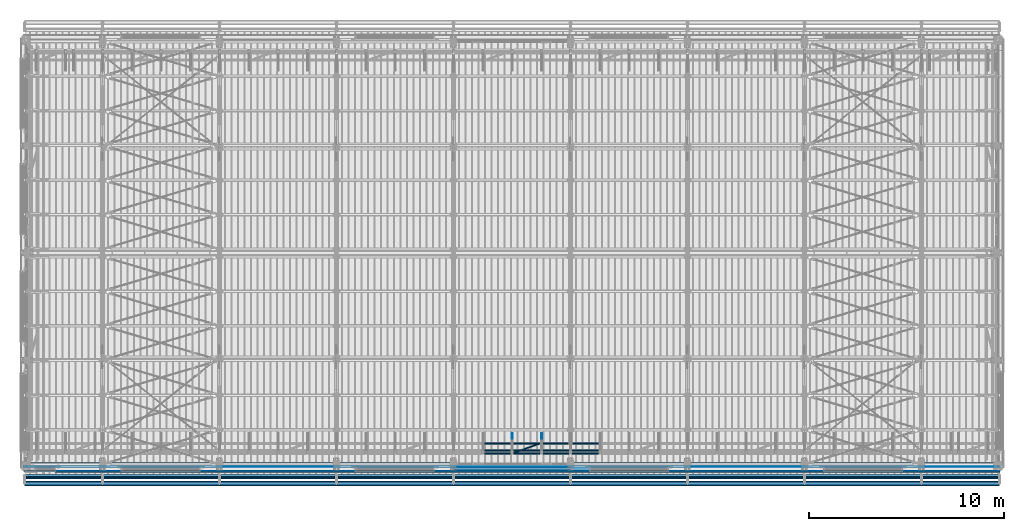
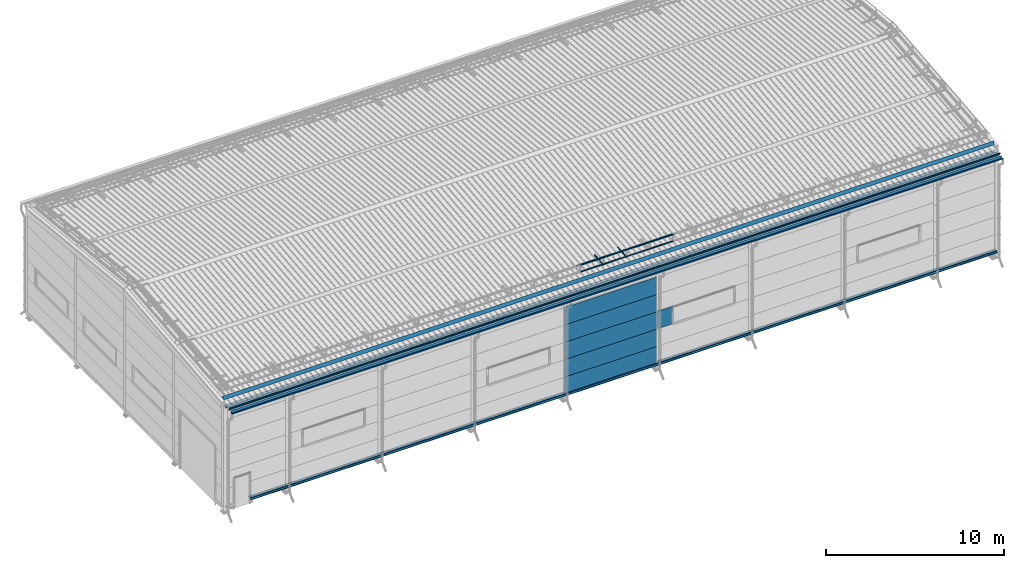
# One storey, part 44 of 709: 21 beams, 21 elements without a shape of their own.
"""IFC4 building model written with IfcOpenShell, lengths in millimetres."""

from ifc_helpers import new_model, si_unit, direction, frame, origin_with_axes, place, context, subcontext, project, spatial, line, indexed_curve, outline, extrude, material, element, aggregate, save


model = new_model("IFC4")

# Units and contexts
model_context = context("Model", 3, precision=0.2, world=origin_with_axes(), true_north=direction((0.0, 1.0)))
body_context = subcontext(model_context, "Body", "Model", "MODEL_VIEW")
ifc_project = project(units=[si_unit("LENGTHUNIT", "METRE", prefix="MILLI"), si_unit("AREAUNIT", "SQUARE_METRE"), si_unit("VOLUMEUNIT", "CUBIC_METRE"), si_unit("MASSUNIT", "GRAM", prefix="KILO"), si_unit("TIMEUNIT", "SECOND"), si_unit("PLANEANGLEUNIT", "RADIAN"), si_unit("SOLIDANGLEUNIT", "STERADIAN"), si_unit("THERMODYNAMICTEMPERATUREUNIT", "DEGREE_CELSIUS"), si_unit("LUMINOUSINTENSITYUNIT", "LUMEN")], contexts=[model_context])

# Site, building, storey
site_placement = place(None, origin_with_axes())
site = spatial("IfcSite", under=ifc_project, at=site_placement, CompositionType="ELEMENT")
building_placement = place(site_placement, origin_with_axes())
building = spatial("IfcBuilding", under=site, at=building_placement, Name="Undefined", CompositionType="ELEMENT")
storey_placement = place(building_placement, origin_with_axes())
storey = spatial("IfcBuildingStorey", under=building, at=storey_placement, Name="Undefined", CompositionType="ELEMENT", Elevation=0.0)

# Assembly, beam
assembly_1_placement = place(storey_placement, frame((50015.0, -503.78213, 7203.66945), z_axis=(0.0, -0.099503719, 0.9950371902), x_axis=(-1.0, 0.0, 0.0)))
assembly_1 = element("IfcElementAssembly", 1, at=assembly_1_placement, inside=storey)
ifc_material_1 = material(Name="Steel_Undefined", Category="STEEL")
beam_1_placement = place(assembly_1_placement, origin_with_axes())
beam_1 = element("IfcBeam", 2, at=beam_1_placement, material=ifc_material_1, context=body_context, shape_type="SolidModel", body=[
    extrude(outline(indexed_curve([(-100.75, -24.25), (-100.75, -124.25), (-100.0, -124.25), (-100.0, -25.0), (100.0, -25.0), (100.0, 25.0), (71.32118, 65.9576), (70.70681, 65.52742), (99.25, 24.76353), (99.25, -24.25)], segments=[line(1, 2, 3, 4, 5, 6, 7, 8, 9, 10, 1)])), frame((0.0, 0.0, 0.0), z_axis=(-1.0, 0.0, 0.0), x_axis=(0.0, 0.0, 1.0)), (0.0, 0.0, -1.0), 49995.0),
])
aggregate(assembly_1, [beam_1])

assembly_2_placement = place(storey_placement, frame((50015.0, 243.64285, 7553.77854), z_axis=(0.0, -0.099503719, 0.9950371902), x_axis=(-1.0, 0.0, 0.0)))
assembly_2 = element("IfcElementAssembly", 3, at=assembly_2_placement, inside=storey)
beam_2_placement = place(assembly_2_placement, origin_with_axes())
beam_2 = element("IfcBeam", 4, at=beam_2_placement, material=ifc_material_1, context=body_context, shape_type="SolidModel", body=[
    extrude(outline(indexed_curve([(-100.0, -1.0), (100.0, -1.0), (-99.18584, 114.0), (-100.18584, 112.26795), (92.5359, 1.0), (-100.0, 1.0)], segments=[line(1, 2, 3, 4, 5, 6, 1)])), frame((0.0, 0.0, 0.0), z_axis=(-1.0, 0.0, 0.0), x_axis=(0.0, 0.0, 1.0)), (0.0, 0.0, -1.0), 49995.0),
])
aggregate(assembly_2, [beam_2])

assembly_3_placement = place(storey_placement, frame((25020.0, 768.92298, 7577.16191), z_axis=(0.0, -0.099503719, 0.9950371902), x_axis=(0.0, 0.9950371902, 0.099503719)))
assembly_3 = element("IfcElementAssembly", 5, at=assembly_3_placement, inside=storey)
beam_3_placement = place(assembly_3_placement, origin_with_axes())
beam_3 = element("IfcBeam", 6, at=beam_3_placement, material=ifc_material_1, ObjectType="601", context=body_context, shape_type="SolidModel", body=[
    extrude(outline(indexed_curve([(-20.0, -25.0), (20.0, -25.0), (20.0, -22.5), (-17.5, -22.5), (-17.5, 22.5), (20.0, 22.5), (20.0, 25.0), (-20.0, 25.0)], segments=[line(1, 2, 3, 4, 5, 6, 7, 8, 1)])), frame((0.0, 0.0, 0.0), z_axis=(-1.0, 0.0, 0.0), x_axis=(0.0, 0.0, 1.0)), (0.0, 0.0, -1.0), 1000.0),
])
aggregate(assembly_3, [beam_3])

assembly_4_placement = place(storey_placement, frame((26520.0, 768.92298, 7577.16191), z_axis=(0.0, -0.099503719, 0.9950371902), x_axis=(0.0, 0.9950371902, 0.099503719)))
assembly_4 = element("IfcElementAssembly", 7, at=assembly_4_placement, inside=storey)
beam_4_placement = place(assembly_4_placement, origin_with_axes())
beam_4 = element("IfcBeam", 8, at=beam_4_placement, material=ifc_material_1, ObjectType="601", context=body_context, shape_type="SolidModel", body=[
    extrude(outline(indexed_curve([(-20.0, -25.0), (20.0, -25.0), (20.0, -22.5), (-17.5, -22.5), (-17.5, 22.5), (20.0, 22.5), (20.0, 25.0), (-20.0, 25.0)], segments=[line(1, 2, 3, 4, 5, 6, 7, 8, 1)])), frame((0.0, 0.0, 0.0), z_axis=(-1.0, 0.0, 0.0), x_axis=(0.0, 0.0, 1.0)), (0.0, 0.0, -1.0), 1000.0),
])
aggregate(assembly_4, [beam_4])

assembly_5_placement = place(storey_placement, frame((23520.0, 691.31008, 8152.29341), z_axis=(0.0, -0.9950371902, -0.099503719), x_axis=(1.0, 0.0, 0.0)))
assembly_5 = element("IfcElementAssembly", 9, at=assembly_5_placement, inside=storey)
beam_5_placement = place(assembly_5_placement, origin_with_axes())
beam_5 = element("IfcBeam", 10, at=beam_5_placement, material=ifc_material_1, ObjectType="606", context=body_context, shape_type="SolidModel", body=[
    extrude(outline(indexed_curve([(-20.0, -25.0), (20.0, -25.0), (20.0, -22.5), (-17.5, -22.5), (-17.5, 22.5), (20.0, 22.5), (20.0, 25.0), (-20.0, 25.0)], segments=[line(1, 2, 3, 4, 5, 6, 7, 8, 1)])), frame((0.0, 0.0, 0.0), z_axis=(-1.0, 0.0, 0.0), x_axis=(0.0, 0.0, 1.0)), (0.0, 0.0, -1.0), 6000.0),
])
aggregate(assembly_5, [beam_5])

assembly_6_placement = place(storey_placement, frame((23520.0, 741.06194, 7654.77481), z_axis=(0.0, -0.9950371902, -0.099503719), x_axis=(1.0, 0.0, 0.0)))
assembly_6 = element("IfcElementAssembly", 11, at=assembly_6_placement, inside=storey)
beam_6_placement = place(assembly_6_placement, origin_with_axes())
beam_6 = element("IfcBeam", 12, at=beam_6_placement, material=ifc_material_1, ObjectType="606", context=body_context, shape_type="SolidModel", body=[
    extrude(outline(indexed_curve([(-20.0, -25.0), (20.0, -25.0), (20.0, -22.5), (-17.5, -22.5), (-17.5, 22.5), (20.0, 22.5), (20.0, 25.0), (-20.0, 25.0)], segments=[line(1, 2, 3, 4, 5, 6, 7, 8, 1)])), frame((0.0, 0.0, 0.0), z_axis=(-1.0, 0.0, 0.0), x_axis=(0.0, 0.0, 1.0)), (0.0, 0.0, -1.0), 6000.0),
])
aggregate(assembly_6, [beam_6])

assembly_7_placement = place(storey_placement, frame((23520.0, 878.66704, 8043.11507), z_axis=(0.0, 0.6332377902, 0.7739572992), x_axis=(1.0, 0.0, 0.0)))
assembly_7 = element("IfcElementAssembly", 13, at=assembly_7_placement, inside=storey)
beam_7_placement = place(assembly_7_placement, origin_with_axes())
beam_7 = element("IfcBeam", 14, at=beam_7_placement, material=ifc_material_1, ObjectType="606", context=body_context, shape_type="SolidModel", body=[
    extrude(outline(indexed_curve([(-20.0, -25.0), (20.0, -25.0), (20.0, -22.5), (-17.5, -22.5), (-17.5, 22.5), (20.0, 22.5), (20.0, 25.0), (-20.0, 25.0)], segments=[line(1, 2, 3, 4, 5, 6, 7, 8, 1)])), frame((0.0, 0.0, 0.0), z_axis=(-1.0, 0.0, 0.0), x_axis=(0.0, 0.0, 1.0)), (0.0, 0.0, -1.0), 6000.0),
])
aggregate(assembly_7, [beam_7])

assembly_8_placement = place(storey_placement, frame((23520.0, 1225.80867, 7759.0901), z_axis=(0.0, 0.6332377902, 0.7739572992), x_axis=(1.0, 0.0, 0.0)))
assembly_8 = element("IfcElementAssembly", 15, at=assembly_8_placement, inside=storey)
beam_8_placement = place(assembly_8_placement, origin_with_axes())
beam_8 = element("IfcBeam", 16, at=beam_8_placement, material=ifc_material_1, ObjectType="606", context=body_context, shape_type="SolidModel", body=[
    extrude(outline(indexed_curve([(-20.0, -25.0), (20.0, -25.0), (20.0, -22.5), (-17.5, -22.5), (-17.5, 22.5), (20.0, 22.5), (20.0, 25.0), (-20.0, 25.0)], segments=[line(1, 2, 3, 4, 5, 6, 7, 8, 1)])), frame((0.0, 0.0, 0.0), z_axis=(-1.0, 0.0, 0.0), x_axis=(0.0, 0.0, 1.0)), (0.0, 0.0, -1.0), 6000.0),
])
aggregate(assembly_8, [beam_8])

assembly_9_placement = place(storey_placement, frame((25020.0, 723.87558, 8169.76263), z_axis=(0.0, 0.6332377902, 0.7739572992), x_axis=(0.9061831398, 0.3272952929, -0.2677870579)))
assembly_9 = element("IfcElementAssembly", 17, at=assembly_9_placement, inside=storey)
beam_9_placement = place(assembly_9_placement, origin_with_axes())
beam_9 = element("IfcBeam", 18, at=beam_9_placement, material=ifc_material_1, ObjectType="605", context=body_context, shape_type="SolidModel", body=[
    extrude(outline(indexed_curve([(-20.0, -25.0), (20.0, -25.0), (20.0, -22.5), (-17.5, -22.5), (-17.5, 22.5), (20.0, 22.5), (20.0, 25.0), (-20.0, 25.0)], segments=[line(1, 2, 3, 4, 5, 6, 7, 8, 1)])), frame((0.0, 0.0, 0.0), z_axis=(-1.0, 0.0, 0.0), x_axis=(0.0, 0.0, 1.0)), (0.0, 0.0, -1.0), 1655.29454),
])
aggregate(assembly_9, [beam_9])

assembly_10_placement = place(storey_placement, frame((22010.0, -60.0, 895.0), z_axis=(0.0, 0.0, -1.0), x_axis=(1.0, 0.0, 0.0)))
assembly_10 = element("IfcElementAssembly", 19, at=assembly_10_placement, inside=storey)
ifc_material_2 = material(Name="Insulation", Category="Insulation")
beam_10_placement = place(assembly_10_placement, origin_with_axes())
beam_10 = element("IfcBeam", 20, at=beam_10_placement, material=ifc_material_2, ObjectType="P-107", context=body_context, shape_type="SolidModel", body=[
    extrude(outline(indexed_curve([(-595.0, -60.0), (595.0, -60.0), (595.0, 60.0), (-595.0, 60.0)], segments=[line(1, 2, 3, 4, 1)])), frame((0.0, 0.0, 0.0), z_axis=(-1.0, 0.0, 0.0), x_axis=(0.0, 0.0, 1.0)), (0.0, 0.0, -1.0), 5980.0),
])
aggregate(assembly_10, [beam_10])

assembly_11_placement = place(storey_placement, frame((22010.0, -60.0, 2085.0), z_axis=(0.0, 0.0, -1.0), x_axis=(1.0, 0.0, 0.0)))
assembly_11 = element("IfcElementAssembly", 21, at=assembly_11_placement, inside=storey)
beam_11_placement = place(assembly_11_placement, origin_with_axes())
beam_11 = element("IfcBeam", 22, at=beam_11_placement, material=ifc_material_2, ObjectType="P-107", context=body_context, shape_type="SolidModel", body=[
    extrude(outline(indexed_curve([(-595.0, -60.0), (595.0, -60.0), (595.0, 60.0), (-595.0, 60.0)], segments=[line(1, 2, 3, 4, 1)])), frame((0.0, 0.0, 0.0), z_axis=(-1.0, 0.0, 0.0), x_axis=(0.0, 0.0, 1.0)), (0.0, 0.0, -1.0), 5980.0),
])
aggregate(assembly_11, [beam_11])

assembly_12_placement = place(storey_placement, frame((22010.0, -60.0, 3275.0), z_axis=(0.0, 0.0, -1.0), x_axis=(1.0, 0.0, 0.0)))
assembly_12 = element("IfcElementAssembly", 23, at=assembly_12_placement, inside=storey)
beam_12_placement = place(assembly_12_placement, origin_with_axes())
beam_12 = element("IfcBeam", 24, at=beam_12_placement, material=ifc_material_2, ObjectType="P-107", context=body_context, shape_type="SolidModel", body=[
    extrude(outline(indexed_curve([(-595.0, -60.0), (595.0, -60.0), (595.0, 60.0), (-595.0, 60.0)], segments=[line(1, 2, 3, 4, 1)])), frame((0.0, 0.0, 0.0), z_axis=(-1.0, 0.0, 0.0), x_axis=(0.0, 0.0, 1.0)), (0.0, 0.0, -1.0), 5980.0),
])
aggregate(assembly_12, [beam_12])

assembly_13_placement = place(storey_placement, frame((22010.0, -60.0, 4465.0), z_axis=(0.0, 0.0, -1.0), x_axis=(1.0, 0.0, 0.0)))
assembly_13 = element("IfcElementAssembly", 25, at=assembly_13_placement, inside=storey)
beam_13_placement = place(assembly_13_placement, origin_with_axes())
beam_13 = element("IfcBeam", 26, at=beam_13_placement, material=ifc_material_2, ObjectType="P-107", context=body_context, shape_type="SolidModel", body=[
    extrude(outline(indexed_curve([(-595.0, -60.0), (595.0, -60.0), (595.0, 60.0), (-595.0, 60.0)], segments=[line(1, 2, 3, 4, 1)])), frame((0.0, 0.0, 0.0), z_axis=(-1.0, 0.0, 0.0), x_axis=(0.0, 0.0, 1.0)), (0.0, 0.0, -1.0), 5980.0),
])
aggregate(assembly_13, [beam_13])

assembly_14_placement = place(storey_placement, frame((22010.0, -60.0, 5655.0), z_axis=(0.0, 0.0, -1.0), x_axis=(1.0, 0.0, 0.0)))
assembly_14 = element("IfcElementAssembly", 27, at=assembly_14_placement, inside=storey)
beam_14_placement = place(assembly_14_placement, origin_with_axes())
beam_14 = element("IfcBeam", 28, at=beam_14_placement, material=ifc_material_2, ObjectType="P-107", context=body_context, shape_type="SolidModel", body=[
    extrude(outline(indexed_curve([(-595.0, -60.0), (595.0, -60.0), (595.0, 60.0), (-595.0, 60.0)], segments=[line(1, 2, 3, 4, 1)])), frame((0.0, 0.0, 0.0), z_axis=(-1.0, 0.0, 0.0), x_axis=(0.0, 0.0, 1.0)), (0.0, 0.0, -1.0), 5980.0),
])
aggregate(assembly_14, [beam_14])

assembly_15_placement = place(storey_placement, frame((28010.0, -60.0, 3275.0), z_axis=(0.0, 0.0, -1.0), x_axis=(1.0, 0.0, 0.0)))
assembly_15 = element("IfcElementAssembly", 29, at=assembly_15_placement, inside=storey)
beam_15_placement = place(assembly_15_placement, origin_with_axes())
beam_15 = element("IfcBeam", 30, at=beam_15_placement, material=ifc_material_2, ObjectType="P-110", context=body_context, shape_type="SolidModel", body=[
    extrude(outline(indexed_curve([(-595.0, -60.0), (595.0, -60.0), (595.0, 60.0), (-595.0, 60.0)], segments=[line(1, 2, 3, 4, 1)])), frame((0.0, 0.0, 0.0), z_axis=(-1.0, 0.0, 0.0), x_axis=(0.0, 0.0, 1.0)), (0.0, 0.0, -1.0), 990.0),
])
aggregate(assembly_15, [beam_15])

assembly_16_placement = place(storey_placement, frame((50000.0, -170.375, 370.0), z_axis=(0.0, 1.0, 0.0), x_axis=(-1.0, 0.0, 0.0)))
assembly_16 = element("IfcElementAssembly", 31, at=assembly_16_placement, inside=storey)
beam_16_placement = place(assembly_16_placement, origin_with_axes())
beam_16 = element("IfcBeam", 32, at=beam_16_placement, material=ifc_material_1, context=body_context, shape_type="SolidModel", body=[
    extrude(outline(indexed_curve([(0.375, -20.0), (0.375, 19.25), (0.495, 19.25), (0.495, 5.0), (1.245, 5.0), (1.245, 20.0), (-0.375, 20.0), (-0.375, -19.68934), (-59.625, -78.93934), (-59.625, -118.93934), (-52.125, -105.94896), (-52.77452, -105.57396), (-58.875, -116.1403), (-58.875, -79.25)], segments=[line(1, 2, 3, 4, 5, 6, 7, 8, 9, 10, 11, 12, 13, 14, 1)])), frame((0.0, 0.0, 0.0), z_axis=(-1.0, 0.0, 0.0), x_axis=(0.0, 0.0, 1.0)), (0.0, 0.0, -1.0), 48420.0),
])
aggregate(assembly_16, [beam_16])

assembly_17_placement = place(storey_placement, frame((1580.0, -155.0, 350.0), z_axis=(0.0, 0.0, -1.0), x_axis=(1.0, 0.0, 0.0)))
assembly_17 = element("IfcElementAssembly", 33, at=assembly_17_placement, inside=storey)
beam_17_placement = place(assembly_17_placement, origin_with_axes())
beam_17 = element("IfcBeam", 34, at=beam_17_placement, material=ifc_material_1, context=body_context, shape_type="SolidModel", body=[
    extrude(outline(indexed_curve([(-35.0, -1.0), (35.0, -1.0), (60.98076, 14.0), (59.98076, 15.73205), (34.4641, 1.0), (-35.0, 1.0)], segments=[line(1, 2, 3, 4, 5, 6, 1)])), frame((0.0, 0.0, 0.0), z_axis=(-1.0, 0.0, 0.0), x_axis=(0.0, 0.0, 1.0)), (0.0, 0.0, -1.0), 48420.0),
])
aggregate(assembly_17, [beam_17])

assembly_18_placement = place(storey_placement, frame((50000.0, 15.0, 350.0), z_axis=(0.0, 0.0, -1.0), x_axis=(-1.0, 0.0, 0.0)))
assembly_18 = element("IfcElementAssembly", 35, at=assembly_18_placement, inside=storey)
beam_18_placement = place(assembly_18_placement, origin_with_axes())
beam_18 = element("IfcBeam", 36, at=beam_18_placement, material=ifc_material_1, context=body_context, shape_type="SolidModel", body=[
    extrude(outline(indexed_curve([(-45.0, -1.0), (45.0, -1.0), (45.0, 49.0), (43.0, 49.0), (43.0, 1.0), (-45.0, 1.0)], segments=[line(1, 2, 3, 4, 5, 6, 1)])), frame((0.0, 0.0, 0.0), z_axis=(-1.0, 0.0, 0.0), x_axis=(0.0, 0.0, 1.0)), (0.0, 0.0, -1.0), 48420.0),
])
aggregate(assembly_18, [beam_18])

assembly_19_placement = place(storey_placement, frame((0.0, 10.0, 7096.92297), z_axis=(0.0, 0.0, 1.0), x_axis=(1.0, 0.0, 0.0)))
assembly_19 = element("IfcElementAssembly", 37, at=assembly_19_placement, inside=storey)
beam_19_placement = place(assembly_19_placement, origin_with_axes())
beam_19 = element("IfcBeam", 38, at=beam_19_placement, material=ifc_material_1, context=body_context, shape_type="SolidModel", body=[
    extrude(outline(indexed_curve([(-67.5, -1.0), (67.5, -1.0), (76.18241, 48.24039), (74.21279, 48.58768), (65.8218, 1.0), (-67.5, 1.0)], segments=[line(1, 2, 3, 4, 5, 6, 1)])), frame((0.0, 0.0, 0.0), z_axis=(-1.0, 0.0, 0.0), x_axis=(0.0, 0.0, 1.0)), (0.0, 0.0, -1.0), 50000.0),
])
aggregate(assembly_19, [beam_19])

assembly_20_placement = place(storey_placement, frame((50000.0, -130.0, 7096.92297), z_axis=(0.0, 0.0, 1.0), x_axis=(-1.0, 0.0, 0.0)))
assembly_20 = element("IfcElementAssembly", 39, at=assembly_20_placement, inside=storey)
beam_20_placement = place(assembly_20_placement, origin_with_axes())
beam_20 = element("IfcBeam", 40, at=beam_20_placement, material=ifc_material_1, context=body_context, shape_type="SolidModel", body=[
    extrude(outline(indexed_curve([(-50.0, -1.0), (50.0, -1.0), (37.81307, 98.25462), (35.82797, 98.01088), (47.73941, 1.0), (-50.0, 1.0)], segments=[line(1, 2, 3, 4, 5, 6, 1)])), frame((0.0, 0.0, 0.0), z_axis=(-1.0, 0.0, 0.0), x_axis=(0.0, 0.0, 1.0)), (0.0, 0.0, -1.0), 50000.0),
])
aggregate(assembly_20, [beam_20])

assembly_21_placement = place(storey_placement, frame((0.0, -820.0, 7096.92297), z_axis=(0.0, -1.0, 0.0), x_axis=(1.0, 0.0, 0.0)))
assembly_21 = element("IfcElementAssembly", 41, at=assembly_21_placement, inside=storey)
beam_21_placement = place(assembly_21_placement, origin_with_axes())
beam_21 = element("IfcBeam", 42, at=beam_21_placement, material=ifc_material_1, context=body_context, shape_type="SolidModel", body=[
    extrude(outline(indexed_curve([(-70.0, -1.0), (70.0, -1.0), (129.16656, 125.88309), (127.35394, 126.72833), (68.72586, 1.0), (-68.72586, 1.0), (-127.35394, 126.72833), (-129.16656, 125.88309)], segments=[line(1, 2, 3, 4, 5, 6, 7, 8, 1)])), frame((0.0, 0.0, 0.0), z_axis=(-1.0, 0.0, 0.0), x_axis=(0.0, 0.0, 1.0)), (0.0, 0.0, -1.0), 50000.0),
])
aggregate(assembly_21, [beam_21])

save(model, "model.ifc")
